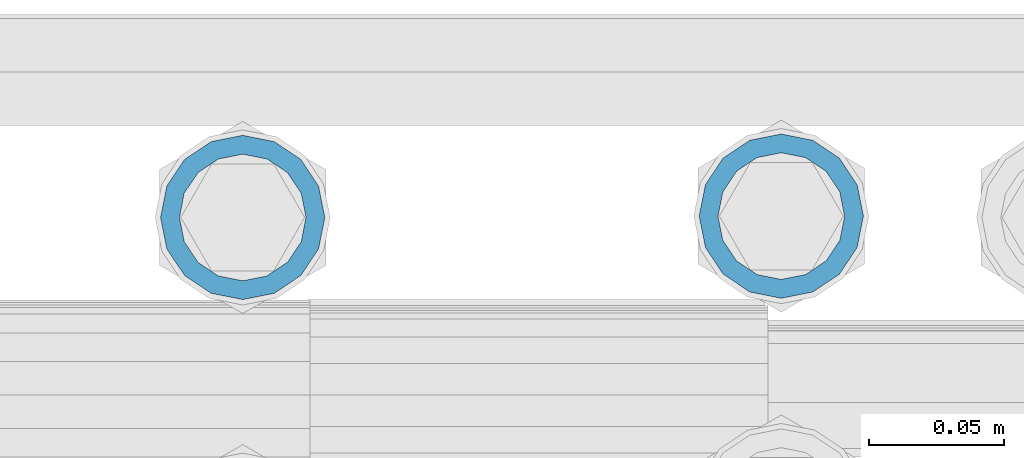
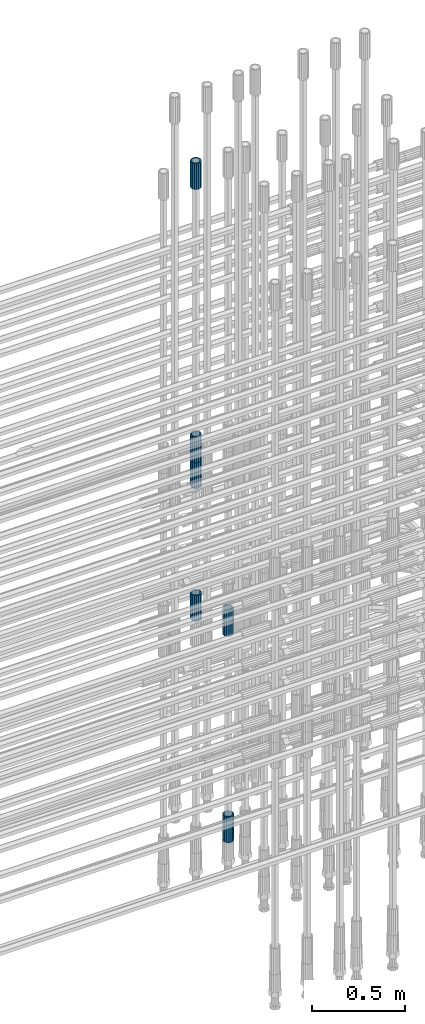
# One storey, part 37 of 119: 6 beams.
"""IFC2X3 building model written with IfcOpenShell, lengths in millimetres."""

from ifc_helpers import new_model, si_unit, frame, origin_with_axes, place, context, subcontext, project, spatial, faceted_brep, material, type_object, element, save


model = new_model("IFC2X3")

# Units and contexts
model_context = context("Model", 3, precision=1e-05, world=origin_with_axes())
body_context = subcontext(model_context, "Body", "Model", "MODEL_VIEW")
ifc_project = project(units=[si_unit("LENGTHUNIT", "METRE", prefix="MILLI"), si_unit("AREAUNIT", "SQUARE_METRE"), si_unit("VOLUMEUNIT", "CUBIC_METRE"), si_unit("MASSUNIT", "GRAM", prefix="KILO"), si_unit("TIMEUNIT", "SECOND"), si_unit("PLANEANGLEUNIT", "RADIAN"), si_unit("SOLIDANGLEUNIT", "STERADIAN"), si_unit("THERMODYNAMICTEMPERATUREUNIT", "DEGREE_CELSIUS"), si_unit("LUMINOUSINTENSITYUNIT", "LUMEN")], contexts=[model_context])

# Site, building, storey
site_placement = place(None, origin_with_axes())
site = spatial("IfcSite", under=ifc_project, at=site_placement, CompositionType="ELEMENT")
building_placement = place(site_placement, origin_with_axes())
building = spatial("IfcBuilding", under=site, at=building_placement, Name="Undefined", CompositionType="ELEMENT")
storey_placement = place(building_placement, origin_with_axes())
storey = spatial("IfcBuildingStorey", under=building, at=storey_placement, Name="Undefined", CompositionType="ELEMENT", Elevation=0.0)

# Beams
ifc_material = material(Name="STEEL/S275")
beam_type = type_object("IfcBeamType", PredefinedType="NOTDEFINED")
beam_1_placement = place(storey_placement, frame((2035324.99866833, 6206345.98579162, 20704.6057291619), z_axis=(1.0, 0.0, 0.0), x_axis=(0.0, 0.0, 1.0)))
element("IfcBeam", 1, at=beam_1_placement, inside=storey, type_object=beam_type, material=ifc_material, Name="AG40N", context=body_context, shape_type="Brep", body=[
    faceted_brep([(1.62981450557709e-09, -23.4999999990687, 0.0), (7.45058059692383e-09, -21.7111690142192, 8.99306066057534), (170.000002125278, -21.711168999318, 8.99306066022245), (170.000002127141, -23.4999999844003, -3.66071617463604e-10), (4.65661287307739e-09, -16.6170093587134, 16.6170093578889), (170.000002122484, -16.6170093440451, 16.6170093575288), (1.86264514923096e-09, -8.99306066217832, 21.7111690140277), (170.000002118759, -8.99306064750999, 21.7111690136603), (2.3283064365387e-10, 9.31322574615479e-10, 23.5), (170.000002114102, 1.28056854009628e-08, 23.4999999996485), (-6.51925802230835e-09, 8.99306065868586, 21.7111690140241), (170.00000211224, 8.99306067335419, 21.7111690136639), (-7.45058059692383e-09, 16.6170093561523, 16.6170093578853), (170.000002109446, 16.6170093708206, 16.6170093575324), (-9.31322574615479e-09, 21.711169013055, 8.99306066057534), (170.000002108514, 21.7111690277234, 8.99306066022245), (-1.16415321826935e-09, 23.5000000009313, 0.0), (170.000002108514, 23.5000000144355, -3.66071617463604e-10), (-8.38190317153931e-09, 21.7111690151505, -8.99306066059444), (170.000002110377, 21.7111690300517, -8.9930606609546), (-5.58793544769287e-09, 16.6170093598776, -16.6170093579008), (170.000002113171, 16.6170093745459, -16.6170093582609), (-9.31322574615479e-10, 8.99306066334248, -21.7111690140396), (170.000002115965, 8.99306067801081, -21.7111690143961), (2.3283064365387e-10, 9.31322574615479e-10, -23.5), (170.00000211969, 1.7927959561348e-08, -23.5000000003843), (5.58793544769287e-09, -8.99306065752171, -21.7111690140396), (170.000002123415, -8.99306064285338, -21.7111690143961), (8.38190317153931e-09, -16.6170093549881, -16.6170093579008), (170.000002125278, -16.6170093403198, -16.6170093582646), (9.31322574615479e-09, -21.7111690121237, -8.99306066059444), (170.000002127141, -21.7111689972226, -8.9930606609546), (1.11758708953857e-08, -30.4999999990687, -9.54969436861575e-12), (1.30385160446167e-08, -28.1783257392235, -11.6718446871514), (170.000002129003, -28.1783257243223, -11.6718446875116), (170.000002129935, -30.4999999841675, -3.66071617463604e-10), (1.02445483207703e-08, -21.5667568228673, -21.5667568262129), (170.000002128072, -21.566756808199, -21.5667568265694), (7.45058059692383e-09, -11.6718446831219, -28.1783257416196), (170.000002125278, -11.6718446684536, -28.1783257419834), (3.72529029846191e-09, 3.95812094211578e-09, -30.5000000000277), (170.00000211969, 1.83936208486557e-08, -30.5000000003879), (-9.31322574615479e-10, 11.6718446905725, -28.1783257416232), (170.000002115965, 11.6718447052408, -28.1783257419797), (-6.51925802230835e-09, 21.5667568286881, -21.5667568262093), (170.000002110377, 21.5667568433564, -21.5667568265694), (-9.31322574615479e-09, 28.178325742716, -11.6718446871478), (170.000002108514, 28.1783257573843, -11.6718446875079), (-1.21071934700012e-08, 30.5, -5.91171556152403e-12), (170.000002106652, 30.5000000144355, -3.62433638656512e-10), (-1.21071934700012e-08, 28.1783257401548, 11.6718446871359), (170.00000210572, 28.1783257548232, 11.6718446867794), (-1.02445483207703e-08, 21.5667568240315, 21.5667568261974), (170.000002107583, 21.566756838467, 21.5667568258409), (-7.45058059692383e-09, 11.671844684286, 28.1783257416041), (170.000002110377, 11.6718446989544, 28.178325741244), (-2.79396772384644e-09, -2.56113708019257e-09, 30.5000000000159), (170.000002114102, 1.18743628263474e-08, 30.4999999996558), (1.86264514923096e-09, -11.6718446896411, 28.1783257416114), (170.000002118759, -11.67184467474, 28.178325741244), (7.45058059692383e-09, -21.5667568275239, 21.5667568261974), (170.000002123415, -21.5667568126228, 21.5667568258373), (1.02445483207703e-08, -28.1783257415518, 11.6718446871359), (170.000002127141, -28.1783257271163, 11.6718446867794)], [[[0, 1, 2, 3]], [[1, 4, 5, 2]], [[4, 6, 7, 5]], [[6, 8, 9, 7]], [[8, 10, 11, 9]], [[10, 12, 13, 11]], [[12, 14, 15, 13]], [[14, 16, 17, 15]], [[16, 18, 19, 17]], [[18, 20, 21, 19]], [[20, 22, 23, 21]], [[22, 24, 25, 23]], [[24, 26, 27, 25]], [[26, 28, 29, 27]], [[28, 30, 31, 29]], [[30, 0, 3, 31]], [[32, 33, 34, 35]], [[33, 36, 37, 34]], [[36, 38, 39, 37]], [[38, 40, 41, 39]], [[40, 42, 43, 41]], [[42, 44, 45, 43]], [[44, 46, 47, 45]], [[46, 48, 49, 47]], [[48, 50, 51, 49]], [[50, 52, 53, 51]], [[52, 54, 55, 53]], [[54, 56, 57, 55]], [[56, 58, 59, 57]], [[58, 60, 61, 59]], [[60, 62, 63, 61]], [[62, 32, 35, 63]], [[37, 39, 41, 43, 45, 47, 49, 51, 53, 55, 57, 59, 61, 63, 35, 34], [5, 7, 9, 11, 13, 15, 17, 19, 21, 23, 25, 27, 29, 31, 3, 2]], [[62, 60, 58, 56, 54, 52, 50, 48, 46, 44, 42, 40, 38, 36, 33, 32], [30, 28, 26, 24, 22, 20, 18, 16, 14, 12, 10, 8, 6, 4, 1, 0]]]),
])
beam_2_placement = place(storey_placement, frame((2035324.99866833, 6206345.98579162, 20007.7168583127), z_axis=(-0.99999999999998, 1.98000110685822e-07, 0.0), x_axis=(0.0, 0.0, -1.0)))
element("IfcBeam", 2, at=beam_2_placement, inside=storey, type_object=beam_type, material=ifc_material, Name="AG40N", context=body_context, shape_type="Brep", body=[
    faceted_brep([(1.62981450557709e-09, -23.4999999990687, 0.0), (7.45058059692383e-09, -21.7111690142192, 8.99306066057534), (170.000002125278, -21.711168999318, 8.99306066022245), (170.000002127141, -23.4999999844003, -3.66071617463604e-10), (4.65661287307739e-09, -16.6170093587134, 16.6170093578889), (170.000002122484, -16.6170093440451, 16.6170093575288), (1.86264514923096e-09, -8.99306066217832, 21.7111690140277), (170.000002118759, -8.99306064750999, 21.7111690136603), (2.3283064365387e-10, 9.31322574615479e-10, 23.5), (170.000002114102, 1.28056854009628e-08, 23.4999999996485), (-6.51925802230835e-09, 8.99306065868586, 21.7111690140241), (170.00000211224, 8.99306067335419, 21.7111690136639), (-7.45058059692383e-09, 16.6170093561523, 16.6170093578853), (170.000002109446, 16.6170093708206, 16.6170093575324), (-9.31322574615479e-09, 21.711169013055, 8.99306066057534), (170.000002108514, 21.7111690277234, 8.99306066022245), (-1.16415321826935e-09, 23.5000000009313, 0.0), (170.000002108514, 23.5000000144355, -3.66071617463604e-10), (-8.38190317153931e-09, 21.7111690151505, -8.99306066059444), (170.000002110377, 21.7111690300517, -8.9930606609546), (-5.58793544769287e-09, 16.6170093598776, -16.6170093579008), (170.000002113171, 16.6170093745459, -16.6170093582609), (-9.31322574615479e-10, 8.99306066334248, -21.7111690140396), (170.000002115965, 8.99306067801081, -21.7111690143961), (2.3283064365387e-10, 9.31322574615479e-10, -23.5), (170.00000211969, 1.7927959561348e-08, -23.5000000003843), (5.58793544769287e-09, -8.99306065752171, -21.7111690140396), (170.000002123415, -8.99306064285338, -21.7111690143961), (8.38190317153931e-09, -16.6170093549881, -16.6170093579008), (170.000002125278, -16.6170093403198, -16.6170093582646), (9.31322574615479e-09, -21.7111690121237, -8.99306066059444), (170.000002127141, -21.7111689972226, -8.9930606609546), (1.11758708953857e-08, -30.4999999990687, -9.54969436861575e-12), (1.30385160446167e-08, -28.1783257392235, -11.6718446871514), (170.000002129003, -28.1783257243223, -11.6718446875116), (170.000002129935, -30.4999999841675, -3.66071617463604e-10), (1.02445483207703e-08, -21.5667568228673, -21.5667568262129), (170.000002128072, -21.566756808199, -21.5667568265694), (7.45058059692383e-09, -11.6718446831219, -28.1783257416196), (170.000002125278, -11.6718446684536, -28.1783257419834), (3.72529029846191e-09, 3.95812094211578e-09, -30.5000000000277), (170.00000211969, 1.83936208486557e-08, -30.5000000003879), (-9.31322574615479e-10, 11.6718446905725, -28.1783257416232), (170.000002115965, 11.6718447052408, -28.1783257419797), (-6.51925802230835e-09, 21.5667568286881, -21.5667568262093), (170.000002110377, 21.5667568433564, -21.5667568265694), (-9.31322574615479e-09, 28.178325742716, -11.6718446871478), (170.000002108514, 28.1783257573843, -11.6718446875079), (-1.21071934700012e-08, 30.5, -5.91171556152403e-12), (170.000002106652, 30.5000000144355, -3.62433638656512e-10), (-1.21071934700012e-08, 28.1783257401548, 11.6718446871359), (170.00000210572, 28.1783257548232, 11.6718446867794), (-1.02445483207703e-08, 21.5667568240315, 21.5667568261974), (170.000002107583, 21.566756838467, 21.5667568258409), (-7.45058059692383e-09, 11.671844684286, 28.1783257416041), (170.000002110377, 11.6718446989544, 28.178325741244), (-2.79396772384644e-09, -2.56113708019257e-09, 30.5000000000159), (170.000002114102, 1.18743628263474e-08, 30.4999999996558), (1.86264514923096e-09, -11.6718446896411, 28.1783257416114), (170.000002118759, -11.67184467474, 28.178325741244), (7.45058059692383e-09, -21.5667568275239, 21.5667568261974), (170.000002123415, -21.5667568126228, 21.5667568258373), (1.02445483207703e-08, -28.1783257415518, 11.6718446871359), (170.000002127141, -28.1783257271163, 11.6718446867794)], [[[0, 1, 2, 3]], [[1, 4, 5, 2]], [[4, 6, 7, 5]], [[6, 8, 9, 7]], [[8, 10, 11, 9]], [[10, 12, 13, 11]], [[12, 14, 15, 13]], [[14, 16, 17, 15]], [[16, 18, 19, 17]], [[18, 20, 21, 19]], [[20, 22, 23, 21]], [[22, 24, 25, 23]], [[24, 26, 27, 25]], [[26, 28, 29, 27]], [[28, 30, 31, 29]], [[30, 0, 3, 31]], [[32, 33, 34, 35]], [[33, 36, 37, 34]], [[36, 38, 39, 37]], [[38, 40, 41, 39]], [[40, 42, 43, 41]], [[42, 44, 45, 43]], [[44, 46, 47, 45]], [[46, 48, 49, 47]], [[48, 50, 51, 49]], [[50, 52, 53, 51]], [[52, 54, 55, 53]], [[54, 56, 57, 55]], [[56, 58, 59, 57]], [[58, 60, 61, 59]], [[60, 62, 63, 61]], [[62, 32, 35, 63]], [[37, 39, 41, 43, 45, 47, 49, 51, 53, 55, 57, 59, 61, 63, 35, 34], [5, 7, 9, 11, 13, 15, 17, 19, 21, 23, 25, 27, 29, 31, 3, 2]], [[62, 60, 58, 56, 54, 52, 50, 48, 46, 44, 42, 40, 38, 36, 33, 32], [30, 28, 26, 24, 22, 20, 18, 16, 14, 12, 10, 8, 6, 4, 1, 0]]]),
])
beam_3_placement = place(storey_placement, frame((2035324.99866833, 6206345.98579162, 22659.9857291619), z_axis=(1.0, 0.0, 0.0), x_axis=(0.0, 0.0, 1.0)))
element("IfcBeam", 3, at=beam_3_placement, inside=storey, type_object=beam_type, material=ifc_material, Name="AG40N", context=body_context, shape_type="Brep", body=[
    faceted_brep([(1.62981450557709e-09, -23.4999999990687, 0.0), (7.45058059692383e-09, -21.7111690142192, 8.99306066057534), (170.000002125278, -21.711168999318, 8.99306066022245), (170.000002127141, -23.4999999844003, -3.66071617463604e-10), (4.65661287307739e-09, -16.6170093587134, 16.6170093578889), (170.000002122484, -16.6170093440451, 16.6170093575288), (1.86264514923096e-09, -8.99306066217832, 21.7111690140277), (170.000002118759, -8.99306064750999, 21.7111690136603), (2.3283064365387e-10, 9.31322574615479e-10, 23.5), (170.000002114102, 1.28056854009628e-08, 23.4999999996485), (-6.51925802230835e-09, 8.99306065868586, 21.7111690140241), (170.00000211224, 8.99306067335419, 21.7111690136639), (-7.45058059692383e-09, 16.6170093561523, 16.6170093578853), (170.000002109446, 16.6170093708206, 16.6170093575324), (-9.31322574615479e-09, 21.711169013055, 8.99306066057534), (170.000002108514, 21.7111690277234, 8.99306066022245), (-1.16415321826935e-09, 23.5000000009313, 0.0), (170.000002108514, 23.5000000144355, -3.66071617463604e-10), (-8.38190317153931e-09, 21.7111690151505, -8.99306066059444), (170.000002110377, 21.7111690300517, -8.9930606609546), (-5.58793544769287e-09, 16.6170093598776, -16.6170093579008), (170.000002113171, 16.6170093745459, -16.6170093582609), (-9.31322574615479e-10, 8.99306066334248, -21.7111690140396), (170.000002115965, 8.99306067801081, -21.7111690143961), (2.3283064365387e-10, 9.31322574615479e-10, -23.5), (170.00000211969, 1.7927959561348e-08, -23.5000000003843), (5.58793544769287e-09, -8.99306065752171, -21.7111690140396), (170.000002123415, -8.99306064285338, -21.7111690143961), (8.38190317153931e-09, -16.6170093549881, -16.6170093579008), (170.000002125278, -16.6170093403198, -16.6170093582646), (9.31322574615479e-09, -21.7111690121237, -8.99306066059444), (170.000002127141, -21.7111689972226, -8.9930606609546), (1.11758708953857e-08, -30.4999999990687, -9.54969436861575e-12), (1.30385160446167e-08, -28.1783257392235, -11.6718446871514), (170.000002129003, -28.1783257243223, -11.6718446875116), (170.000002129935, -30.4999999841675, -3.66071617463604e-10), (1.02445483207703e-08, -21.5667568228673, -21.5667568262129), (170.000002128072, -21.566756808199, -21.5667568265694), (7.45058059692383e-09, -11.6718446831219, -28.1783257416196), (170.000002125278, -11.6718446684536, -28.1783257419834), (3.72529029846191e-09, 3.95812094211578e-09, -30.5000000000277), (170.00000211969, 1.83936208486557e-08, -30.5000000003879), (-9.31322574615479e-10, 11.6718446905725, -28.1783257416232), (170.000002115965, 11.6718447052408, -28.1783257419797), (-6.51925802230835e-09, 21.5667568286881, -21.5667568262093), (170.000002110377, 21.5667568433564, -21.5667568265694), (-9.31322574615479e-09, 28.178325742716, -11.6718446871478), (170.000002108514, 28.1783257573843, -11.6718446875079), (-1.21071934700012e-08, 30.5, -5.91171556152403e-12), (170.000002106652, 30.5000000144355, -3.62433638656512e-10), (-1.21071934700012e-08, 28.1783257401548, 11.6718446871359), (170.00000210572, 28.1783257548232, 11.6718446867794), (-1.02445483207703e-08, 21.5667568240315, 21.5667568261974), (170.000002107583, 21.566756838467, 21.5667568258409), (-7.45058059692383e-09, 11.671844684286, 28.1783257416041), (170.000002110377, 11.6718446989544, 28.178325741244), (-2.79396772384644e-09, -2.56113708019257e-09, 30.5000000000159), (170.000002114102, 1.18743628263474e-08, 30.4999999996558), (1.86264514923096e-09, -11.6718446896411, 28.1783257416114), (170.000002118759, -11.67184467474, 28.178325741244), (7.45058059692383e-09, -21.5667568275239, 21.5667568261974), (170.000002123415, -21.5667568126228, 21.5667568258373), (1.02445483207703e-08, -28.1783257415518, 11.6718446871359), (170.000002127141, -28.1783257271163, 11.6718446867794)], [[[0, 1, 2, 3]], [[1, 4, 5, 2]], [[4, 6, 7, 5]], [[6, 8, 9, 7]], [[8, 10, 11, 9]], [[10, 12, 13, 11]], [[12, 14, 15, 13]], [[14, 16, 17, 15]], [[16, 18, 19, 17]], [[18, 20, 21, 19]], [[20, 22, 23, 21]], [[22, 24, 25, 23]], [[24, 26, 27, 25]], [[26, 28, 29, 27]], [[28, 30, 31, 29]], [[30, 0, 3, 31]], [[32, 33, 34, 35]], [[33, 36, 37, 34]], [[36, 38, 39, 37]], [[38, 40, 41, 39]], [[40, 42, 43, 41]], [[42, 44, 45, 43]], [[44, 46, 47, 45]], [[46, 48, 49, 47]], [[48, 50, 51, 49]], [[50, 52, 53, 51]], [[52, 54, 55, 53]], [[54, 56, 57, 55]], [[56, 58, 59, 57]], [[58, 60, 61, 59]], [[60, 62, 63, 61]], [[62, 32, 35, 63]], [[37, 39, 41, 43, 45, 47, 49, 51, 53, 55, 57, 59, 61, 63, 35, 34], [5, 7, 9, 11, 13, 15, 17, 19, 21, 23, 25, 27, 29, 31, 3, 2]], [[62, 60, 58, 56, 54, 52, 50, 48, 46, 44, 42, 40, 38, 36, 33, 32], [30, 28, 26, 24, 22, 20, 18, 16, 14, 12, 10, 8, 6, 4, 1, 0]]]),
])
beam_4_placement = place(storey_placement, frame((2035324.99866833, 6206345.98579162, 21044.6068583121), z_axis=(-0.99999999999998, 1.98000110685822e-07, 0.0), x_axis=(0.0, 0.0, -1.0)))
element("IfcBeam", 4, at=beam_4_placement, inside=storey, type_object=beam_type, material=ifc_material, Name="AG40N", context=body_context, shape_type="Brep", body=[
    faceted_brep([(1.62981450557709e-09, -23.4999999990687, 0.0), (7.45058059692383e-09, -21.7111690142192, 8.99306066057534), (170.000002125278, -21.711168999318, 8.99306066022245), (170.000002127141, -23.4999999844003, -3.66071617463604e-10), (4.65661287307739e-09, -16.6170093587134, 16.6170093578889), (170.000002122484, -16.6170093440451, 16.6170093575288), (1.86264514923096e-09, -8.99306066217832, 21.7111690140277), (170.000002118759, -8.99306064750999, 21.7111690136603), (2.3283064365387e-10, 9.31322574615479e-10, 23.5), (170.000002114102, 1.28056854009628e-08, 23.4999999996485), (-6.51925802230835e-09, 8.99306065868586, 21.7111690140241), (170.00000211224, 8.99306067335419, 21.7111690136639), (-7.45058059692383e-09, 16.6170093561523, 16.6170093578853), (170.000002109446, 16.6170093708206, 16.6170093575324), (-9.31322574615479e-09, 21.711169013055, 8.99306066057534), (170.000002108514, 21.7111690277234, 8.99306066022245), (-1.16415321826935e-09, 23.5000000009313, 0.0), (170.000002108514, 23.5000000144355, -3.66071617463604e-10), (-8.38190317153931e-09, 21.7111690151505, -8.99306066059444), (170.000002110377, 21.7111690300517, -8.9930606609546), (-5.58793544769287e-09, 16.6170093598776, -16.6170093579008), (170.000002113171, 16.6170093745459, -16.6170093582609), (-9.31322574615479e-10, 8.99306066334248, -21.7111690140396), (170.000002115965, 8.99306067801081, -21.7111690143961), (2.3283064365387e-10, 9.31322574615479e-10, -23.5), (170.00000211969, 1.7927959561348e-08, -23.5000000003843), (5.58793544769287e-09, -8.99306065752171, -21.7111690140396), (170.000002123415, -8.99306064285338, -21.7111690143961), (8.38190317153931e-09, -16.6170093549881, -16.6170093579008), (170.000002125278, -16.6170093403198, -16.6170093582646), (9.31322574615479e-09, -21.7111690121237, -8.99306066059444), (170.000002127141, -21.7111689972226, -8.9930606609546), (1.11758708953857e-08, -30.4999999990687, -9.54969436861575e-12), (1.30385160446167e-08, -28.1783257392235, -11.6718446871514), (170.000002129003, -28.1783257243223, -11.6718446875116), (170.000002129935, -30.4999999841675, -3.66071617463604e-10), (1.02445483207703e-08, -21.5667568228673, -21.5667568262129), (170.000002128072, -21.566756808199, -21.5667568265694), (7.45058059692383e-09, -11.6718446831219, -28.1783257416196), (170.000002125278, -11.6718446684536, -28.1783257419834), (3.72529029846191e-09, 3.95812094211578e-09, -30.5000000000277), (170.00000211969, 1.83936208486557e-08, -30.5000000003879), (-9.31322574615479e-10, 11.6718446905725, -28.1783257416232), (170.000002115965, 11.6718447052408, -28.1783257419797), (-6.51925802230835e-09, 21.5667568286881, -21.5667568262093), (170.000002110377, 21.5667568433564, -21.5667568265694), (-9.31322574615479e-09, 28.178325742716, -11.6718446871478), (170.000002108514, 28.1783257573843, -11.6718446875079), (-1.21071934700012e-08, 30.5, -5.91171556152403e-12), (170.000002106652, 30.5000000144355, -3.62433638656512e-10), (-1.21071934700012e-08, 28.1783257401548, 11.6718446871359), (170.00000210572, 28.1783257548232, 11.6718446867794), (-1.02445483207703e-08, 21.5667568240315, 21.5667568261974), (170.000002107583, 21.566756838467, 21.5667568258409), (-7.45058059692383e-09, 11.671844684286, 28.1783257416041), (170.000002110377, 11.6718446989544, 28.178325741244), (-2.79396772384644e-09, -2.56113708019257e-09, 30.5000000000159), (170.000002114102, 1.18743628263474e-08, 30.4999999996558), (1.86264514923096e-09, -11.6718446896411, 28.1783257416114), (170.000002118759, -11.67184467474, 28.178325741244), (7.45058059692383e-09, -21.5667568275239, 21.5667568261974), (170.000002123415, -21.5667568126228, 21.5667568258373), (1.02445483207703e-08, -28.1783257415518, 11.6718446871359), (170.000002127141, -28.1783257271163, 11.6718446867794)], [[[0, 1, 2, 3]], [[1, 4, 5, 2]], [[4, 6, 7, 5]], [[6, 8, 9, 7]], [[8, 10, 11, 9]], [[10, 12, 13, 11]], [[12, 14, 15, 13]], [[14, 16, 17, 15]], [[16, 18, 19, 17]], [[18, 20, 21, 19]], [[20, 22, 23, 21]], [[22, 24, 25, 23]], [[24, 26, 27, 25]], [[26, 28, 29, 27]], [[28, 30, 31, 29]], [[30, 0, 3, 31]], [[32, 33, 34, 35]], [[33, 36, 37, 34]], [[36, 38, 39, 37]], [[38, 40, 41, 39]], [[40, 42, 43, 41]], [[42, 44, 45, 43]], [[44, 46, 47, 45]], [[46, 48, 49, 47]], [[48, 50, 51, 49]], [[50, 52, 53, 51]], [[52, 54, 55, 53]], [[54, 56, 57, 55]], [[56, 58, 59, 57]], [[58, 60, 61, 59]], [[60, 62, 63, 61]], [[62, 32, 35, 63]], [[37, 39, 41, 43, 45, 47, 49, 51, 53, 55, 57, 59, 61, 63, 35, 34], [5, 7, 9, 11, 13, 15, 17, 19, 21, 23, 25, 27, 29, 31, 3, 2]], [[62, 60, 58, 56, 54, 52, 50, 48, 46, 44, 42, 40, 38, 36, 33, 32], [30, 28, 26, 24, 22, 20, 18, 16, 14, 12, 10, 8, 6, 4, 1, 0]]]),
])
beam_5_placement = place(storey_placement, frame((2035524.9984776, 6206346.48575538, 19667.7157291642), z_axis=(1.0, 0.0, 0.0), x_axis=(0.0, 0.0, 1.0)))
element("IfcBeam", 5, at=beam_5_placement, inside=storey, type_object=beam_type, material=ifc_material, Name="AG40N", context=body_context, shape_type="Brep", body=[
    faceted_brep([(1.62981450557709e-09, -23.4999999990687, 0.0), (7.45058059692383e-09, -21.7111690142192, 8.99306066057534), (170.000002125278, -21.711168999318, 8.99306066022245), (170.000002127141, -23.4999999844003, -3.66071617463604e-10), (4.65661287307739e-09, -16.6170093587134, 16.6170093578889), (170.000002122484, -16.6170093440451, 16.6170093575288), (1.86264514923096e-09, -8.99306066217832, 21.7111690140277), (170.000002118759, -8.99306064750999, 21.7111690136603), (2.3283064365387e-10, 9.31322574615479e-10, 23.5), (170.000002114102, 1.28056854009628e-08, 23.4999999996485), (-6.51925802230835e-09, 8.99306065868586, 21.7111690140241), (170.00000211224, 8.99306067335419, 21.7111690136639), (-7.45058059692383e-09, 16.6170093561523, 16.6170093578853), (170.000002109446, 16.6170093708206, 16.6170093575324), (-9.31322574615479e-09, 21.711169013055, 8.99306066057534), (170.000002108514, 21.7111690277234, 8.99306066022245), (-1.16415321826935e-09, 23.5000000009313, 0.0), (170.000002108514, 23.5000000144355, -3.66071617463604e-10), (-8.38190317153931e-09, 21.7111690151505, -8.99306066059444), (170.000002110377, 21.7111690300517, -8.9930606609546), (-5.58793544769287e-09, 16.6170093598776, -16.6170093579008), (170.000002113171, 16.6170093745459, -16.6170093582609), (-9.31322574615479e-10, 8.99306066334248, -21.7111690140396), (170.000002115965, 8.99306067801081, -21.7111690143961), (2.3283064365387e-10, 9.31322574615479e-10, -23.5), (170.00000211969, 1.7927959561348e-08, -23.5000000003843), (5.58793544769287e-09, -8.99306065752171, -21.7111690140396), (170.000002123415, -8.99306064285338, -21.7111690143961), (8.38190317153931e-09, -16.6170093549881, -16.6170093579008), (170.000002125278, -16.6170093403198, -16.6170093582646), (9.31322574615479e-09, -21.7111690121237, -8.99306066059444), (170.000002127141, -21.7111689972226, -8.9930606609546), (1.11758708953857e-08, -30.4999999990687, -9.54969436861575e-12), (1.30385160446167e-08, -28.1783257392235, -11.6718446871514), (170.000002129003, -28.1783257243223, -11.6718446875116), (170.000002129935, -30.4999999841675, -3.66071617463604e-10), (1.02445483207703e-08, -21.5667568228673, -21.5667568262129), (170.000002128072, -21.566756808199, -21.5667568265694), (7.45058059692383e-09, -11.6718446831219, -28.1783257416196), (170.000002125278, -11.6718446684536, -28.1783257419834), (3.72529029846191e-09, 3.95812094211578e-09, -30.5000000000277), (170.00000211969, 1.83936208486557e-08, -30.5000000003879), (-9.31322574615479e-10, 11.6718446905725, -28.1783257416232), (170.000002115965, 11.6718447052408, -28.1783257419797), (-6.51925802230835e-09, 21.5667568286881, -21.5667568262093), (170.000002110377, 21.5667568433564, -21.5667568265694), (-9.31322574615479e-09, 28.178325742716, -11.6718446871478), (170.000002108514, 28.1783257573843, -11.6718446875079), (-1.21071934700012e-08, 30.5, -5.91171556152403e-12), (170.000002106652, 30.5000000144355, -3.62433638656512e-10), (-1.21071934700012e-08, 28.1783257401548, 11.6718446871359), (170.00000210572, 28.1783257548232, 11.6718446867794), (-1.02445483207703e-08, 21.5667568240315, 21.5667568261974), (170.000002107583, 21.566756838467, 21.5667568258409), (-7.45058059692383e-09, 11.671844684286, 28.1783257416041), (170.000002110377, 11.6718446989544, 28.178325741244), (-2.79396772384644e-09, -2.56113708019257e-09, 30.5000000000159), (170.000002114102, 1.18743628263474e-08, 30.4999999996558), (1.86264514923096e-09, -11.6718446896411, 28.1783257416114), (170.000002118759, -11.67184467474, 28.178325741244), (7.45058059692383e-09, -21.5667568275239, 21.5667568261974), (170.000002123415, -21.5667568126228, 21.5667568258373), (1.02445483207703e-08, -28.1783257415518, 11.6718446871359), (170.000002127141, -28.1783257271163, 11.6718446867794)], [[[0, 1, 2, 3]], [[1, 4, 5, 2]], [[4, 6, 7, 5]], [[6, 8, 9, 7]], [[8, 10, 11, 9]], [[10, 12, 13, 11]], [[12, 14, 15, 13]], [[14, 16, 17, 15]], [[16, 18, 19, 17]], [[18, 20, 21, 19]], [[20, 22, 23, 21]], [[22, 24, 25, 23]], [[24, 26, 27, 25]], [[26, 28, 29, 27]], [[28, 30, 31, 29]], [[30, 0, 3, 31]], [[32, 33, 34, 35]], [[33, 36, 37, 34]], [[36, 38, 39, 37]], [[38, 40, 41, 39]], [[40, 42, 43, 41]], [[42, 44, 45, 43]], [[44, 46, 47, 45]], [[46, 48, 49, 47]], [[48, 50, 51, 49]], [[50, 52, 53, 51]], [[52, 54, 55, 53]], [[54, 56, 57, 55]], [[56, 58, 59, 57]], [[58, 60, 61, 59]], [[60, 62, 63, 61]], [[62, 32, 35, 63]], [[37, 39, 41, 43, 45, 47, 49, 51, 53, 55, 57, 59, 61, 63, 35, 34], [5, 7, 9, 11, 13, 15, 17, 19, 21, 23, 25, 27, 29, 31, 3, 2]], [[62, 60, 58, 56, 54, 52, 50, 48, 46, 44, 42, 40, 38, 36, 33, 32], [30, 28, 26, 24, 22, 20, 18, 16, 14, 12, 10, 8, 6, 4, 1, 0]]]),
])
beam_6_placement = place(storey_placement, frame((2035524.9984776, 6206346.48575538, 18490.966858315), z_axis=(-0.99999999999998, 1.98000110685822e-07, 0.0), x_axis=(0.0, 0.0, -1.0)))
element("IfcBeam", 6, at=beam_6_placement, inside=storey, type_object=beam_type, material=ifc_material, Name="AG40N", context=body_context, shape_type="Brep", body=[
    faceted_brep([(1.62981450557709e-09, -23.4999999990687, 0.0), (7.45058059692383e-09, -21.7111690142192, 8.99306066057534), (170.000002125278, -21.711168999318, 8.99306066022245), (170.000002127141, -23.4999999844003, -3.66071617463604e-10), (4.65661287307739e-09, -16.6170093587134, 16.6170093578889), (170.000002122484, -16.6170093440451, 16.6170093575288), (1.86264514923096e-09, -8.99306066217832, 21.7111690140277), (170.000002118759, -8.99306064750999, 21.7111690136603), (2.3283064365387e-10, 9.31322574615479e-10, 23.5), (170.000002114102, 1.28056854009628e-08, 23.4999999996485), (-6.51925802230835e-09, 8.99306065868586, 21.7111690140241), (170.00000211224, 8.99306067335419, 21.7111690136639), (-7.45058059692383e-09, 16.6170093561523, 16.6170093578853), (170.000002109446, 16.6170093708206, 16.6170093575324), (-9.31322574615479e-09, 21.711169013055, 8.99306066057534), (170.000002108514, 21.7111690277234, 8.99306066022245), (-1.16415321826935e-09, 23.5000000009313, 0.0), (170.000002108514, 23.5000000144355, -3.66071617463604e-10), (-8.38190317153931e-09, 21.7111690151505, -8.99306066059444), (170.000002110377, 21.7111690300517, -8.9930606609546), (-5.58793544769287e-09, 16.6170093598776, -16.6170093579008), (170.000002113171, 16.6170093745459, -16.6170093582609), (-9.31322574615479e-10, 8.99306066334248, -21.7111690140396), (170.000002115965, 8.99306067801081, -21.7111690143961), (2.3283064365387e-10, 9.31322574615479e-10, -23.5), (170.00000211969, 1.7927959561348e-08, -23.5000000003843), (5.58793544769287e-09, -8.99306065752171, -21.7111690140396), (170.000002123415, -8.99306064285338, -21.7111690143961), (8.38190317153931e-09, -16.6170093549881, -16.6170093579008), (170.000002125278, -16.6170093403198, -16.6170093582646), (9.31322574615479e-09, -21.7111690121237, -8.99306066059444), (170.000002127141, -21.7111689972226, -8.9930606609546), (1.11758708953857e-08, -30.4999999990687, -9.54969436861575e-12), (1.30385160446167e-08, -28.1783257392235, -11.6718446871514), (170.000002129003, -28.1783257243223, -11.6718446875116), (170.000002129935, -30.4999999841675, -3.66071617463604e-10), (1.02445483207703e-08, -21.5667568228673, -21.5667568262129), (170.000002128072, -21.566756808199, -21.5667568265694), (7.45058059692383e-09, -11.6718446831219, -28.1783257416196), (170.000002125278, -11.6718446684536, -28.1783257419834), (3.72529029846191e-09, 3.95812094211578e-09, -30.5000000000277), (170.00000211969, 1.83936208486557e-08, -30.5000000003879), (-9.31322574615479e-10, 11.6718446905725, -28.1783257416232), (170.000002115965, 11.6718447052408, -28.1783257419797), (-6.51925802230835e-09, 21.5667568286881, -21.5667568262093), (170.000002110377, 21.5667568433564, -21.5667568265694), (-9.31322574615479e-09, 28.178325742716, -11.6718446871478), (170.000002108514, 28.1783257573843, -11.6718446875079), (-1.21071934700012e-08, 30.5, -5.91171556152403e-12), (170.000002106652, 30.5000000144355, -3.62433638656512e-10), (-1.21071934700012e-08, 28.1783257401548, 11.6718446871359), (170.00000210572, 28.1783257548232, 11.6718446867794), (-1.02445483207703e-08, 21.5667568240315, 21.5667568261974), (170.000002107583, 21.566756838467, 21.5667568258409), (-7.45058059692383e-09, 11.671844684286, 28.1783257416041), (170.000002110377, 11.6718446989544, 28.178325741244), (-2.79396772384644e-09, -2.56113708019257e-09, 30.5000000000159), (170.000002114102, 1.18743628263474e-08, 30.4999999996558), (1.86264514923096e-09, -11.6718446896411, 28.1783257416114), (170.000002118759, -11.67184467474, 28.178325741244), (7.45058059692383e-09, -21.5667568275239, 21.5667568261974), (170.000002123415, -21.5667568126228, 21.5667568258373), (1.02445483207703e-08, -28.1783257415518, 11.6718446871359), (170.000002127141, -28.1783257271163, 11.6718446867794)], [[[0, 1, 2, 3]], [[1, 4, 5, 2]], [[4, 6, 7, 5]], [[6, 8, 9, 7]], [[8, 10, 11, 9]], [[10, 12, 13, 11]], [[12, 14, 15, 13]], [[14, 16, 17, 15]], [[16, 18, 19, 17]], [[18, 20, 21, 19]], [[20, 22, 23, 21]], [[22, 24, 25, 23]], [[24, 26, 27, 25]], [[26, 28, 29, 27]], [[28, 30, 31, 29]], [[30, 0, 3, 31]], [[32, 33, 34, 35]], [[33, 36, 37, 34]], [[36, 38, 39, 37]], [[38, 40, 41, 39]], [[40, 42, 43, 41]], [[42, 44, 45, 43]], [[44, 46, 47, 45]], [[46, 48, 49, 47]], [[48, 50, 51, 49]], [[50, 52, 53, 51]], [[52, 54, 55, 53]], [[54, 56, 57, 55]], [[56, 58, 59, 57]], [[58, 60, 61, 59]], [[60, 62, 63, 61]], [[62, 32, 35, 63]], [[37, 39, 41, 43, 45, 47, 49, 51, 53, 55, 57, 59, 61, 63, 35, 34], [5, 7, 9, 11, 13, 15, 17, 19, 21, 23, 25, 27, 29, 31, 3, 2]], [[62, 60, 58, 56, 54, 52, 50, 48, 46, 44, 42, 40, 38, 36, 33, 32], [30, 28, 26, 24, 22, 20, 18, 16, 14, 12, 10, 8, 6, 4, 1, 0]]]),
])

save(model, "model.ifc")
